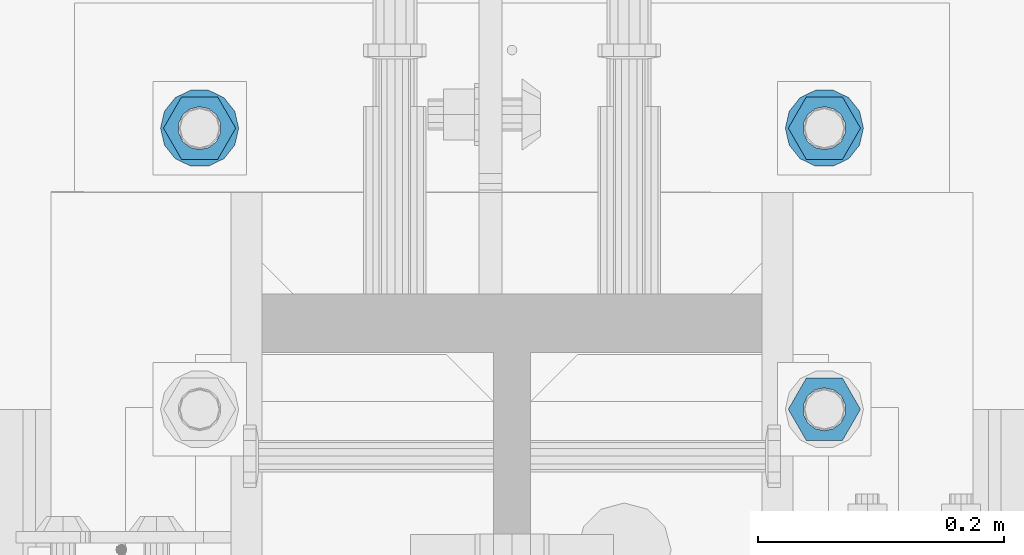
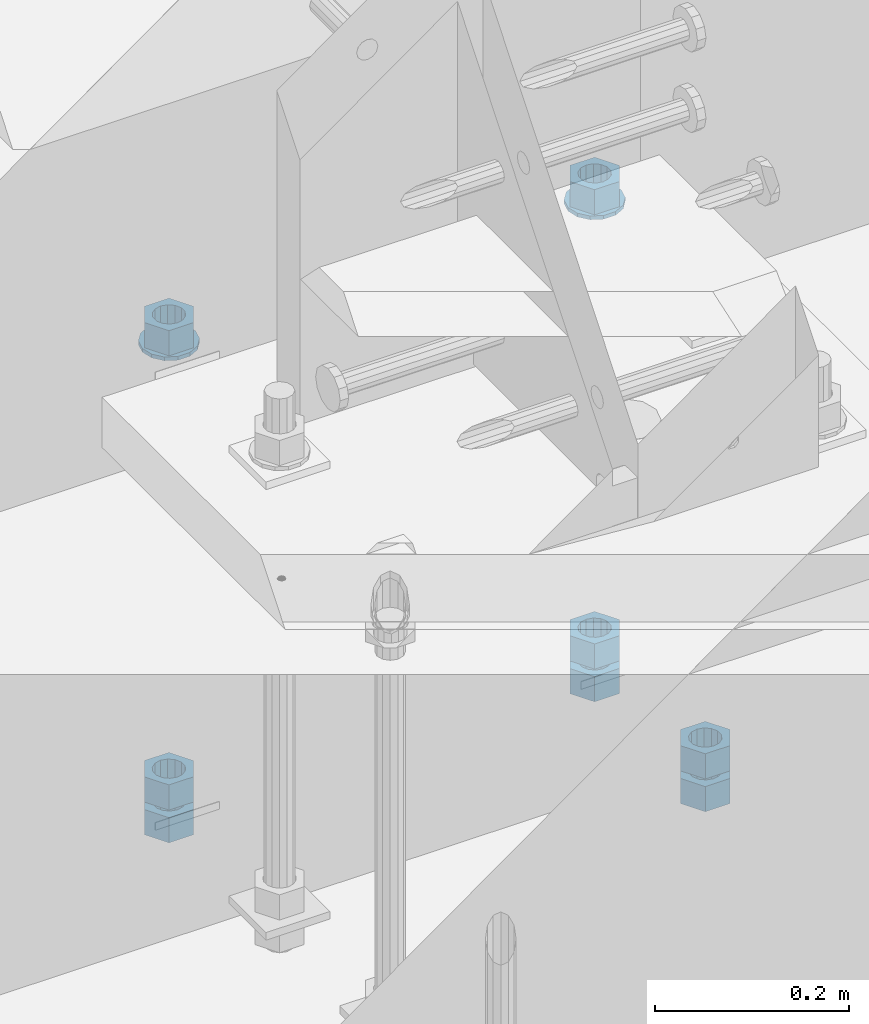
# One storey, part 1015 of 1763: 10 columns, 1 element without a shape of its own.
"""IFC2X3 building model written with IfcOpenShell, lengths in millimetres."""

from ifc_helpers import new_model, si_unit, frame, origin_with_axes, place, context, subcontext, project, spatial, faceted_brep, material, type_object, element, aggregate, save


model = new_model("IFC2X3")

# Units and contexts
model_context = context("Model", 3, precision=1e-05, world=origin_with_axes())
body_context = subcontext(model_context, "Body", "Model", "MODEL_VIEW")
ifc_project = project(units=[si_unit("LENGTHUNIT", "METRE", prefix="MILLI"), si_unit("AREAUNIT", "SQUARE_METRE"), si_unit("VOLUMEUNIT", "CUBIC_METRE"), si_unit("MASSUNIT", "GRAM", prefix="KILO"), si_unit("TIMEUNIT", "SECOND"), si_unit("PLANEANGLEUNIT", "RADIAN"), si_unit("SOLIDANGLEUNIT", "STERADIAN"), si_unit("THERMODYNAMICTEMPERATUREUNIT", "DEGREE_CELSIUS"), si_unit("LUMINOUSINTENSITYUNIT", "LUMEN")], contexts=[model_context])

# Site, building, storey
site_placement = place(None, origin_with_axes())
site = spatial("IfcSite", under=ifc_project, at=site_placement, CompositionType="ELEMENT")
building_placement = place(site_placement, origin_with_axes())
building = spatial("IfcBuilding", under=site, at=building_placement, Name="Undefined", CompositionType="ELEMENT")
storey_placement = place(building_placement, origin_with_axes())
storey = spatial("IfcBuildingStorey", under=building, at=storey_placement, Name="Undefined", CompositionType="ELEMENT", Elevation=0.0)

# Assembly, columns
assembly_placement = place(storey_placement, origin_with_axes())
assembly = element("IfcElementAssembly", 1, at=assembly_placement, inside=storey, Name="TEMPLATE", AssemblyPlace="NOTDEFINED", PredefinedType="RIGID_FRAME")
ifc_material_1 = material(Name="STEEL/A563")
column_type_1 = type_object("IfcColumnType", Name="1-1/4_HEAVY_HEX_NUT", PredefinedType="NOTDEFINED")
column_1_placement = place(assembly_placement, frame((-23773.8372736984, 13804.8999999999, 3384.55), z_axis=(0.0, 1.0, 0.0), x_axis=(0.0, 0.0, -1.0)))
column_1 = element("IfcColumn", 2, at=column_1_placement, type_object=column_type_1, material=ifc_material_1, Name="NUT", ObjectType="1-1/4_HEAVY_HEX_NUT", context=body_context, shape_type="Brep", body=[
    faceted_brep([(0.0, -29.3700008392334, 0.0), (0.0, -14.6800003051758, -25.4300003051758), (31.75, -14.6800003051758, -25.4300003051758), (31.75, -29.3700008392334, 0.0), (0.0, 14.6800003051758, -25.4300003051758), (31.75, 14.6800003051758, -25.4300003051758), (0.0, 29.3700008392334, 0.0), (31.75, 29.3700008392334, 0.0), (0.0, 14.6800003051758, 25.4300003051758), (31.75, 14.6800003051758, 25.4300003051758), (0.0, -14.6800003051758, 25.4300003051758), (31.75, -14.6800003051758, 25.4300003051758), (0.0, 0.0, 17.4599990844727), (0.0, 7.57560968776022, 15.730915608714), (31.75, 7.57560968775942, 15.7309156087145), (31.75, 0.0, 17.4599990844727), (0.0, 13.6507769681037, 10.8861313696252), (31.75, 13.6507769681048, 10.8861313696314), (0.0, 17.0222404541215, 3.88521530314756), (31.75, 17.02224045412, 3.88521530315316), (0.0, 17.0222404541215, -3.88521530314756), (31.75, 17.02224045412, -3.88521530315332), (0.0, 13.6507769681037, -10.8861313696252), (31.75, 13.6507769681048, -10.8861313696316), (0.0, 7.57560968776022, -15.730915608714), (31.75, 7.57560968775942, -15.7309156087146), (0.0, 0.0, -17.4599990844727), (31.75, 0.0, -17.4599990844727), (0.0, -7.57560968776022, -15.730915608714), (31.75, -7.57560968775942, -15.7309156087145), (0.0, -13.6507769681037, -10.8861313696252), (31.75, -13.6507769681048, -10.8861313696314), (0.0, -17.0222404541215, -3.88521530314756), (31.75, -17.02224045412, -3.88521530315316), (0.0, -17.0222404541215, 3.88521530314756), (31.75, -17.02224045412, 3.88521530315332), (0.0, -13.6507769681037, 10.8861313696252), (31.75, -13.6507769681048, 10.8861313696316), (0.0, -7.57560968776022, 15.730915608714), (31.75, -7.57560968775942, 15.7309156087146)], [[[0, 1, 2, 3]], [[1, 4, 5, 2]], [[4, 6, 7, 5]], [[6, 8, 9, 7]], [[8, 10, 11, 9]], [[10, 0, 3, 11]], [[12, 13, 14, 15]], [[13, 16, 17, 14]], [[16, 18, 19, 17]], [[18, 20, 21, 19]], [[20, 22, 23, 21]], [[22, 24, 25, 23]], [[24, 26, 27, 25]], [[26, 28, 29, 27]], [[28, 30, 31, 29]], [[30, 32, 33, 31]], [[32, 34, 35, 33]], [[34, 36, 37, 35]], [[36, 38, 39, 37]], [[38, 12, 15, 39]], [[5, 7, 9, 11, 3, 2], [17, 19, 21, 23, 25, 27, 29, 31, 33, 35, 37, 39, 15, 14]], [[10, 8, 6, 4, 1, 0], [38, 36, 34, 32, 30, 28, 26, 24, 22, 20, 18, 16, 13, 12]]]),
])
column_2_placement = place(assembly_placement, frame((-23773.8372736984, 13804.8999999999, 3343.275), z_axis=(0.0, 1.0, 0.0), x_axis=(0.0, 0.0, -1.0)))
column_2 = element("IfcColumn", 3, at=column_2_placement, type_object=column_type_1, material=ifc_material_1, Name="NUT", ObjectType="1-1/4_HEAVY_HEX_NUT", context=body_context, shape_type="Brep", body=[
    faceted_brep([(0.0, -29.3700008392334, 0.0), (0.0, -14.6800003051758, -25.4300003051758), (31.75, -14.6800003051758, -25.4300003051758), (31.75, -29.3700008392334, 0.0), (0.0, 14.6800003051758, -25.4300003051758), (31.75, 14.6800003051758, -25.4300003051758), (0.0, 29.3700008392334, 0.0), (31.75, 29.3700008392334, 0.0), (0.0, 14.6800003051758, 25.4300003051758), (31.75, 14.6800003051758, 25.4300003051758), (0.0, -14.6800003051758, 25.4300003051758), (31.75, -14.6800003051758, 25.4300003051758), (0.0, 0.0, 17.4599990844727), (0.0, 7.57560968776022, 15.730915608714), (31.75, 7.57560968775942, 15.7309156087145), (31.75, 0.0, 17.4599990844727), (0.0, 13.6507769681037, 10.8861313696252), (31.75, 13.6507769681048, 10.8861313696314), (0.0, 17.0222404541215, 3.88521530314756), (31.75, 17.02224045412, 3.88521530315316), (0.0, 17.0222404541215, -3.88521530314756), (31.75, 17.02224045412, -3.88521530315332), (0.0, 13.6507769681037, -10.8861313696252), (31.75, 13.6507769681048, -10.8861313696316), (0.0, 7.57560968776022, -15.730915608714), (31.75, 7.57560968775942, -15.7309156087146), (0.0, 0.0, -17.4599990844727), (31.75, 0.0, -17.4599990844727), (0.0, -7.57560968776022, -15.730915608714), (31.75, -7.57560968775942, -15.7309156087145), (0.0, -13.6507769681037, -10.8861313696252), (31.75, -13.6507769681048, -10.8861313696314), (0.0, -17.0222404541215, -3.88521530314756), (31.75, -17.02224045412, -3.88521530315316), (0.0, -17.0222404541215, 3.88521530314756), (31.75, -17.02224045412, 3.88521530315332), (0.0, -13.6507769681037, 10.8861313696252), (31.75, -13.6507769681048, 10.8861313696316), (0.0, -7.57560968776022, 15.730915608714), (31.75, -7.57560968775942, 15.7309156087146)], [[[0, 1, 2, 3]], [[1, 4, 5, 2]], [[4, 6, 7, 5]], [[6, 8, 9, 7]], [[8, 10, 11, 9]], [[10, 0, 3, 11]], [[12, 13, 14, 15]], [[13, 16, 17, 14]], [[16, 18, 19, 17]], [[18, 20, 21, 19]], [[20, 22, 23, 21]], [[22, 24, 25, 23]], [[24, 26, 27, 25]], [[26, 28, 29, 27]], [[28, 30, 31, 29]], [[30, 32, 33, 31]], [[32, 34, 35, 33]], [[34, 36, 37, 35]], [[36, 38, 39, 37]], [[38, 12, 15, 39]], [[5, 7, 9, 11, 3, 2], [17, 19, 21, 23, 25, 27, 29, 31, 33, 35, 37, 39, 15, 14]], [[10, 8, 6, 4, 1, 0], [38, 36, 34, 32, 30, 28, 26, 24, 22, 20, 18, 16, 13, 12]]]),
])
column_3_placement = place(assembly_placement, frame((-24281.8372736984, 14033.4999999999, 3957.6375), z_axis=(0.0, -1.0, 0.0), x_axis=(0.0, 0.0, -1.0)))
column_3 = element("IfcColumn", 4, at=column_3_placement, type_object=column_type_1, material=ifc_material_1, Name="NUT", ObjectType="1-1/4_HEAVY_HEX_NUT", context=body_context, shape_type="Brep", body=[
    faceted_brep([(0.0, -29.3700008392334, 0.0), (0.0, -14.6800003051758, -25.4300003051758), (31.75, -14.6800003051758, -25.4300003051758), (31.75, -29.3700008392334, 0.0), (0.0, 14.6800003051758, -25.4300003051758), (31.75, 14.6800003051758, -25.4300003051758), (0.0, 29.3700008392334, 0.0), (31.75, 29.3700008392334, 0.0), (0.0, 14.6800003051758, 25.4300003051758), (31.75, 14.6800003051758, 25.4300003051758), (0.0, -14.6800003051758, 25.4300003051758), (31.75, -14.6800003051758, 25.4300003051758), (0.0, 0.0, 17.4599990844727), (0.0, 7.57560968776022, 15.730915608714), (31.75, 7.57560968775942, 15.7309156087145), (31.75, 0.0, 17.4599990844727), (0.0, 13.6507769681037, 10.8861313696252), (31.75, 13.6507769681048, 10.8861313696314), (0.0, 17.0222404541215, 3.88521530314756), (31.75, 17.02224045412, 3.88521530315316), (0.0, 17.0222404541215, -3.88521530314756), (31.75, 17.02224045412, -3.88521530315332), (0.0, 13.6507769681037, -10.8861313696252), (31.75, 13.6507769681048, -10.8861313696316), (0.0, 7.57560968776022, -15.730915608714), (31.75, 7.57560968775942, -15.7309156087146), (0.0, 0.0, -17.4599990844727), (31.75, 0.0, -17.4599990844727), (0.0, -7.57560968776022, -15.730915608714), (31.75, -7.57560968775942, -15.7309156087145), (0.0, -13.6507769681037, -10.8861313696252), (31.75, -13.6507769681048, -10.8861313696314), (0.0, -17.0222404541215, -3.88521530314756), (31.75, -17.02224045412, -3.88521530315316), (0.0, -17.0222404541215, 3.88521530314756), (31.75, -17.02224045412, 3.88521530315332), (0.0, -13.6507769681037, 10.8861313696252), (31.75, -13.6507769681048, 10.8861313696316), (0.0, -7.57560968776022, 15.730915608714), (31.75, -7.57560968775942, 15.7309156087146)], [[[0, 1, 2, 3]], [[1, 4, 5, 2]], [[4, 6, 7, 5]], [[6, 8, 9, 7]], [[8, 10, 11, 9]], [[10, 0, 3, 11]], [[12, 13, 14, 15]], [[13, 16, 17, 14]], [[16, 18, 19, 17]], [[18, 20, 21, 19]], [[20, 22, 23, 21]], [[22, 24, 25, 23]], [[24, 26, 27, 25]], [[26, 28, 29, 27]], [[28, 30, 31, 29]], [[30, 32, 33, 31]], [[32, 34, 35, 33]], [[34, 36, 37, 35]], [[36, 38, 39, 37]], [[38, 12, 15, 39]], [[5, 7, 9, 11, 3, 2], [17, 19, 21, 23, 25, 27, 29, 31, 33, 35, 37, 39, 15, 14]], [[10, 8, 6, 4, 1, 0], [38, 36, 34, 32, 30, 28, 26, 24, 22, 20, 18, 16, 13, 12]]]),
])
column_4_placement = place(assembly_placement, frame((-24281.8372736984, 14033.4999999999, 3384.55), z_axis=(0.0, -1.0, 0.0), x_axis=(0.0, 0.0, -1.0)))
column_4 = element("IfcColumn", 5, at=column_4_placement, type_object=column_type_1, material=ifc_material_1, Name="NUT", ObjectType="1-1/4_HEAVY_HEX_NUT", context=body_context, shape_type="Brep", body=[
    faceted_brep([(0.0, -29.3700008392334, 0.0), (0.0, -14.6800003051758, -25.4300003051758), (31.75, -14.6800003051758, -25.4300003051758), (31.75, -29.3700008392334, 0.0), (0.0, 14.6800003051758, -25.4300003051758), (31.75, 14.6800003051758, -25.4300003051758), (0.0, 29.3700008392334, 0.0), (31.75, 29.3700008392334, 0.0), (0.0, 14.6800003051758, 25.4300003051758), (31.75, 14.6800003051758, 25.4300003051758), (0.0, -14.6800003051758, 25.4300003051758), (31.75, -14.6800003051758, 25.4300003051758), (0.0, 0.0, 17.4599990844727), (0.0, 7.57560968776022, 15.730915608714), (31.75, 7.57560968775942, 15.7309156087145), (31.75, 0.0, 17.4599990844727), (0.0, 13.6507769681037, 10.8861313696252), (31.75, 13.6507769681048, 10.8861313696314), (0.0, 17.0222404541215, 3.88521530314756), (31.75, 17.02224045412, 3.88521530315316), (0.0, 17.0222404541215, -3.88521530314756), (31.75, 17.02224045412, -3.88521530315332), (0.0, 13.6507769681037, -10.8861313696252), (31.75, 13.6507769681048, -10.8861313696316), (0.0, 7.57560968776022, -15.730915608714), (31.75, 7.57560968775942, -15.7309156087146), (0.0, 0.0, -17.4599990844727), (31.75, 0.0, -17.4599990844727), (0.0, -7.57560968776022, -15.730915608714), (31.75, -7.57560968775942, -15.7309156087145), (0.0, -13.6507769681037, -10.8861313696252), (31.75, -13.6507769681048, -10.8861313696314), (0.0, -17.0222404541215, -3.88521530314756), (31.75, -17.02224045412, -3.88521530315316), (0.0, -17.0222404541215, 3.88521530314756), (31.75, -17.02224045412, 3.88521530315332), (0.0, -13.6507769681037, 10.8861313696252), (31.75, -13.6507769681048, 10.8861313696316), (0.0, -7.57560968776022, 15.730915608714), (31.75, -7.57560968775942, 15.7309156087146)], [[[0, 1, 2, 3]], [[1, 4, 5, 2]], [[4, 6, 7, 5]], [[6, 8, 9, 7]], [[8, 10, 11, 9]], [[10, 0, 3, 11]], [[12, 13, 14, 15]], [[13, 16, 17, 14]], [[16, 18, 19, 17]], [[18, 20, 21, 19]], [[20, 22, 23, 21]], [[22, 24, 25, 23]], [[24, 26, 27, 25]], [[26, 28, 29, 27]], [[28, 30, 31, 29]], [[30, 32, 33, 31]], [[32, 34, 35, 33]], [[34, 36, 37, 35]], [[36, 38, 39, 37]], [[38, 12, 15, 39]], [[5, 7, 9, 11, 3, 2], [17, 19, 21, 23, 25, 27, 29, 31, 33, 35, 37, 39, 15, 14]], [[10, 8, 6, 4, 1, 0], [38, 36, 34, 32, 30, 28, 26, 24, 22, 20, 18, 16, 13, 12]]]),
])
column_5_placement = place(assembly_placement, frame((-24281.8372736984, 14033.4999999999, 3343.275), z_axis=(0.0, -1.0, 0.0), x_axis=(0.0, 0.0, -1.0)))
column_5 = element("IfcColumn", 6, at=column_5_placement, type_object=column_type_1, material=ifc_material_1, Name="NUT", ObjectType="1-1/4_HEAVY_HEX_NUT", context=body_context, shape_type="Brep", body=[
    faceted_brep([(0.0, -29.3700008392334, 0.0), (0.0, -14.6800003051758, -25.4300003051758), (31.75, -14.6800003051758, -25.4300003051758), (31.75, -29.3700008392334, 0.0), (0.0, 14.6800003051758, -25.4300003051758), (31.75, 14.6800003051758, -25.4300003051758), (0.0, 29.3700008392334, 0.0), (31.75, 29.3700008392334, 0.0), (0.0, 14.6800003051758, 25.4300003051758), (31.75, 14.6800003051758, 25.4300003051758), (0.0, -14.6800003051758, 25.4300003051758), (31.75, -14.6800003051758, 25.4300003051758), (0.0, 0.0, 17.4599990844727), (0.0, 7.57560968776022, 15.730915608714), (31.75, 7.57560968775942, 15.7309156087145), (31.75, 0.0, 17.4599990844727), (0.0, 13.6507769681037, 10.8861313696252), (31.75, 13.6507769681048, 10.8861313696314), (0.0, 17.0222404541215, 3.88521530314756), (31.75, 17.02224045412, 3.88521530315316), (0.0, 17.0222404541215, -3.88521530314756), (31.75, 17.02224045412, -3.88521530315332), (0.0, 13.6507769681037, -10.8861313696252), (31.75, 13.6507769681048, -10.8861313696316), (0.0, 7.57560968776022, -15.730915608714), (31.75, 7.57560968775942, -15.7309156087146), (0.0, 0.0, -17.4599990844727), (31.75, 0.0, -17.4599990844727), (0.0, -7.57560968776022, -15.730915608714), (31.75, -7.57560968775942, -15.7309156087145), (0.0, -13.6507769681037, -10.8861313696252), (31.75, -13.6507769681048, -10.8861313696314), (0.0, -17.0222404541215, -3.88521530314756), (31.75, -17.02224045412, -3.88521530315316), (0.0, -17.0222404541215, 3.88521530314756), (31.75, -17.02224045412, 3.88521530315332), (0.0, -13.6507769681037, 10.8861313696252), (31.75, -13.6507769681048, 10.8861313696316), (0.0, -7.57560968776022, 15.730915608714), (31.75, -7.57560968775942, 15.7309156087146)], [[[0, 1, 2, 3]], [[1, 4, 5, 2]], [[4, 6, 7, 5]], [[6, 8, 9, 7]], [[8, 10, 11, 9]], [[10, 0, 3, 11]], [[12, 13, 14, 15]], [[13, 16, 17, 14]], [[16, 18, 19, 17]], [[18, 20, 21, 19]], [[20, 22, 23, 21]], [[22, 24, 25, 23]], [[24, 26, 27, 25]], [[26, 28, 29, 27]], [[28, 30, 31, 29]], [[30, 32, 33, 31]], [[32, 34, 35, 33]], [[34, 36, 37, 35]], [[36, 38, 39, 37]], [[38, 12, 15, 39]], [[5, 7, 9, 11, 3, 2], [17, 19, 21, 23, 25, 27, 29, 31, 33, 35, 37, 39, 15, 14]], [[10, 8, 6, 4, 1, 0], [38, 36, 34, 32, 30, 28, 26, 24, 22, 20, 18, 16, 13, 12]]]),
])
column_6_placement = place(assembly_placement, frame((-23773.8372736984, 14033.4999999999, 3957.6375), z_axis=(0.0, 1.0, 0.0), x_axis=(0.0, 0.0, -1.0)))
column_6 = element("IfcColumn", 7, at=column_6_placement, type_object=column_type_1, material=ifc_material_1, Name="NUT", ObjectType="1-1/4_HEAVY_HEX_NUT", context=body_context, shape_type="Brep", body=[
    faceted_brep([(0.0, -29.3700008392334, 0.0), (0.0, -14.6800003051758, -25.4300003051758), (31.75, -14.6800003051758, -25.4300003051758), (31.75, -29.3700008392334, 0.0), (0.0, 14.6800003051758, -25.4300003051758), (31.75, 14.6800003051758, -25.4300003051758), (0.0, 29.3700008392334, 0.0), (31.75, 29.3700008392334, 0.0), (0.0, 14.6800003051758, 25.4300003051758), (31.75, 14.6800003051758, 25.4300003051758), (0.0, -14.6800003051758, 25.4300003051758), (31.75, -14.6800003051758, 25.4300003051758), (0.0, 0.0, 17.4599990844727), (0.0, 7.57560968776022, 15.730915608714), (31.75, 7.57560968775942, 15.7309156087145), (31.75, 0.0, 17.4599990844727), (0.0, 13.6507769681037, 10.8861313696252), (31.75, 13.6507769681048, 10.8861313696314), (0.0, 17.0222404541215, 3.88521530314756), (31.75, 17.02224045412, 3.88521530315316), (0.0, 17.0222404541215, -3.88521530314756), (31.75, 17.02224045412, -3.88521530315332), (0.0, 13.6507769681037, -10.8861313696252), (31.75, 13.6507769681048, -10.8861313696316), (0.0, 7.57560968776022, -15.730915608714), (31.75, 7.57560968775942, -15.7309156087146), (0.0, 0.0, -17.4599990844727), (31.75, 0.0, -17.4599990844727), (0.0, -7.57560968776022, -15.730915608714), (31.75, -7.57560968775942, -15.7309156087145), (0.0, -13.6507769681037, -10.8861313696252), (31.75, -13.6507769681048, -10.8861313696314), (0.0, -17.0222404541215, -3.88521530314756), (31.75, -17.02224045412, -3.88521530315316), (0.0, -17.0222404541215, 3.88521530314756), (31.75, -17.02224045412, 3.88521530315332), (0.0, -13.6507769681037, 10.8861313696252), (31.75, -13.6507769681048, 10.8861313696316), (0.0, -7.57560968776022, 15.730915608714), (31.75, -7.57560968775942, 15.7309156087146)], [[[0, 1, 2, 3]], [[1, 4, 5, 2]], [[4, 6, 7, 5]], [[6, 8, 9, 7]], [[8, 10, 11, 9]], [[10, 0, 3, 11]], [[12, 13, 14, 15]], [[13, 16, 17, 14]], [[16, 18, 19, 17]], [[18, 20, 21, 19]], [[20, 22, 23, 21]], [[22, 24, 25, 23]], [[24, 26, 27, 25]], [[26, 28, 29, 27]], [[28, 30, 31, 29]], [[30, 32, 33, 31]], [[32, 34, 35, 33]], [[34, 36, 37, 35]], [[36, 38, 39, 37]], [[38, 12, 15, 39]], [[5, 7, 9, 11, 3, 2], [17, 19, 21, 23, 25, 27, 29, 31, 33, 35, 37, 39, 15, 14]], [[10, 8, 6, 4, 1, 0], [38, 36, 34, 32, 30, 28, 26, 24, 22, 20, 18, 16, 13, 12]]]),
])
column_7_placement = place(assembly_placement, frame((-23773.8372736984, 14033.4999999999, 3384.55), z_axis=(0.0, 1.0, 0.0), x_axis=(0.0, 0.0, -1.0)))
column_7 = element("IfcColumn", 8, at=column_7_placement, type_object=column_type_1, material=ifc_material_1, Name="NUT", ObjectType="1-1/4_HEAVY_HEX_NUT", context=body_context, shape_type="Brep", body=[
    faceted_brep([(0.0, -29.3700008392334, 0.0), (0.0, -14.6800003051758, -25.4300003051758), (31.75, -14.6800003051758, -25.4300003051758), (31.75, -29.3700008392334, 0.0), (0.0, 14.6800003051758, -25.4300003051758), (31.75, 14.6800003051758, -25.4300003051758), (0.0, 29.3700008392334, 0.0), (31.75, 29.3700008392334, 0.0), (0.0, 14.6800003051758, 25.4300003051758), (31.75, 14.6800003051758, 25.4300003051758), (0.0, -14.6800003051758, 25.4300003051758), (31.75, -14.6800003051758, 25.4300003051758), (0.0, 0.0, 17.4599990844727), (0.0, 7.57560968776022, 15.730915608714), (31.75, 7.57560968775942, 15.7309156087145), (31.75, 0.0, 17.4599990844727), (0.0, 13.6507769681037, 10.8861313696252), (31.75, 13.6507769681048, 10.8861313696314), (0.0, 17.0222404541215, 3.88521530314756), (31.75, 17.02224045412, 3.88521530315316), (0.0, 17.0222404541215, -3.88521530314756), (31.75, 17.02224045412, -3.88521530315332), (0.0, 13.6507769681037, -10.8861313696252), (31.75, 13.6507769681048, -10.8861313696316), (0.0, 7.57560968776022, -15.730915608714), (31.75, 7.57560968775942, -15.7309156087146), (0.0, 0.0, -17.4599990844727), (31.75, 0.0, -17.4599990844727), (0.0, -7.57560968776022, -15.730915608714), (31.75, -7.57560968775942, -15.7309156087145), (0.0, -13.6507769681037, -10.8861313696252), (31.75, -13.6507769681048, -10.8861313696314), (0.0, -17.0222404541215, -3.88521530314756), (31.75, -17.02224045412, -3.88521530315316), (0.0, -17.0222404541215, 3.88521530314756), (31.75, -17.02224045412, 3.88521530315332), (0.0, -13.6507769681037, 10.8861313696252), (31.75, -13.6507769681048, 10.8861313696316), (0.0, -7.57560968776022, 15.730915608714), (31.75, -7.57560968775942, 15.7309156087146)], [[[0, 1, 2, 3]], [[1, 4, 5, 2]], [[4, 6, 7, 5]], [[6, 8, 9, 7]], [[8, 10, 11, 9]], [[10, 0, 3, 11]], [[12, 13, 14, 15]], [[13, 16, 17, 14]], [[16, 18, 19, 17]], [[18, 20, 21, 19]], [[20, 22, 23, 21]], [[22, 24, 25, 23]], [[24, 26, 27, 25]], [[26, 28, 29, 27]], [[28, 30, 31, 29]], [[30, 32, 33, 31]], [[32, 34, 35, 33]], [[34, 36, 37, 35]], [[36, 38, 39, 37]], [[38, 12, 15, 39]], [[5, 7, 9, 11, 3, 2], [17, 19, 21, 23, 25, 27, 29, 31, 33, 35, 37, 39, 15, 14]], [[10, 8, 6, 4, 1, 0], [38, 36, 34, 32, 30, 28, 26, 24, 22, 20, 18, 16, 13, 12]]]),
])
column_8_placement = place(assembly_placement, frame((-23773.8372736984, 14033.4999999999, 3343.275), z_axis=(0.0, 1.0, 0.0), x_axis=(0.0, 0.0, -1.0)))
column_8 = element("IfcColumn", 9, at=column_8_placement, type_object=column_type_1, material=ifc_material_1, Name="NUT", ObjectType="1-1/4_HEAVY_HEX_NUT", context=body_context, shape_type="Brep", body=[
    faceted_brep([(0.0, -29.3700008392334, 0.0), (0.0, -14.6800003051758, -25.4300003051758), (31.75, -14.6800003051758, -25.4300003051758), (31.75, -29.3700008392334, 0.0), (0.0, 14.6800003051758, -25.4300003051758), (31.75, 14.6800003051758, -25.4300003051758), (0.0, 29.3700008392334, 0.0), (31.75, 29.3700008392334, 0.0), (0.0, 14.6800003051758, 25.4300003051758), (31.75, 14.6800003051758, 25.4300003051758), (0.0, -14.6800003051758, 25.4300003051758), (31.75, -14.6800003051758, 25.4300003051758), (0.0, 0.0, 17.4599990844727), (0.0, 7.57560968776022, 15.730915608714), (31.75, 7.57560968775942, 15.7309156087145), (31.75, 0.0, 17.4599990844727), (0.0, 13.6507769681037, 10.8861313696252), (31.75, 13.6507769681048, 10.8861313696314), (0.0, 17.0222404541215, 3.88521530314756), (31.75, 17.02224045412, 3.88521530315316), (0.0, 17.0222404541215, -3.88521530314756), (31.75, 17.02224045412, -3.88521530315332), (0.0, 13.6507769681037, -10.8861313696252), (31.75, 13.6507769681048, -10.8861313696316), (0.0, 7.57560968776022, -15.730915608714), (31.75, 7.57560968775942, -15.7309156087146), (0.0, 0.0, -17.4599990844727), (31.75, 0.0, -17.4599990844727), (0.0, -7.57560968776022, -15.730915608714), (31.75, -7.57560968775942, -15.7309156087145), (0.0, -13.6507769681037, -10.8861313696252), (31.75, -13.6507769681048, -10.8861313696314), (0.0, -17.0222404541215, -3.88521530314756), (31.75, -17.02224045412, -3.88521530315316), (0.0, -17.0222404541215, 3.88521530314756), (31.75, -17.02224045412, 3.88521530315332), (0.0, -13.6507769681037, 10.8861313696252), (31.75, -13.6507769681048, 10.8861313696316), (0.0, -7.57560968776022, 15.730915608714), (31.75, -7.57560968775942, 15.7309156087146)], [[[0, 1, 2, 3]], [[1, 4, 5, 2]], [[4, 6, 7, 5]], [[6, 8, 9, 7]], [[8, 10, 11, 9]], [[10, 0, 3, 11]], [[12, 13, 14, 15]], [[13, 16, 17, 14]], [[16, 18, 19, 17]], [[18, 20, 21, 19]], [[20, 22, 23, 21]], [[22, 24, 25, 23]], [[24, 26, 27, 25]], [[26, 28, 29, 27]], [[28, 30, 31, 29]], [[30, 32, 33, 31]], [[32, 34, 35, 33]], [[34, 36, 37, 35]], [[36, 38, 39, 37]], [[38, 12, 15, 39]], [[5, 7, 9, 11, 3, 2], [17, 19, 21, 23, 25, 27, 29, 31, 33, 35, 37, 39, 15, 14]], [[10, 8, 6, 4, 1, 0], [38, 36, 34, 32, 30, 28, 26, 24, 22, 20, 18, 16, 13, 12]]]),
])
ifc_material_2 = material(Name="STEEL/F436")
column_type_2 = type_object("IfcColumnType", Name="1-1/4_WASHER", PredefinedType="NOTDEFINED")
column_9_placement = place(assembly_placement, frame((-24281.8372736984, 14033.4999999999, 3925.8875), z_axis=(0.0, -1.0, 0.0), x_axis=(0.0, 0.0, -1.0)))
column_9 = element("IfcColumn", 10, at=column_9_placement, type_object=column_type_2, material=ifc_material_2, Name="WASHER", ObjectType="1-1/4_WASHER", context=body_context, shape_type="Brep", body=[
    faceted_brep([(-4.54747350886464e-13, -31.7499999999964, 0.0), (0.0, -28.6057615559002, -13.7758087169827), (4.76249999999982, -28.6057615559002, -13.7758087169827), (4.76249999999982, -31.75, 0.0), (0.0, -19.795801209013, -24.8231495683602), (4.76249999999982, -19.795801209013, -24.8231495683602), (0.0, -7.06503965311276, -30.9539612117732), (4.76249999999982, -7.06503965311276, -30.9539612117732), (0.0, 7.06503965311276, -30.9539612117732), (4.76249999999982, 7.06503965311276, -30.9539612117732), (0.0, 19.7958012090166, -24.8231495683602), (4.76249999999982, 19.7958012090166, -24.8231495683602), (0.0, 28.6057615559039, -13.7758087169827), (4.76249999999982, 28.6057615559039, -13.7758087169827), (-5.91171556152403e-12, 31.7499999999891, 0.0), (4.76249999999982, 31.75, 0.0), (0.0, 28.6057615559002, 13.7758087169827), (4.76249999999982, 28.6057615559002, 13.7758087169827), (0.0, 19.795801209013, 24.8231495683602), (4.76249999999982, 19.795801209013, 24.8231495683602), (0.0, 7.06503965311276, 30.9539612117731), (4.76249999999982, 7.06503965311276, 30.9539612117731), (0.0, -7.06503965311276, 30.9539612117731), (4.76249999999982, -7.06503965311276, 30.9539612117731), (0.0, -19.7958012090166, 24.8231495683602), (4.76249999999982, -19.7958012090166, 24.8231495683602), (0.0, -28.6057615559039, 13.7758087169827), (4.76249999999982, -28.6057615559039, 13.7758087169827), (0.0, 0.0, 17.4599990844727), (0.0, 7.57560968776022, 15.730915608714), (4.76249999999982, 7.57560968775942, 15.7309156087145), (4.76249999999982, 0.0, 17.4599990844727), (0.0, 13.6507769681037, 10.8861313696252), (4.76249999999982, 13.6507769681048, 10.8861313696314), (0.0, 17.0222404541215, 3.88521530314756), (4.76249999999982, 17.02224045412, 3.88521530315316), (0.0, 17.0222404541215, -3.88521530314756), (4.76249999999982, 17.02224045412, -3.88521530315332), (0.0, 13.6507769681037, -10.8861313696252), (4.76249999999982, 13.6507769681048, -10.8861313696316), (0.0, 7.57560968776022, -15.730915608714), (4.76249999999982, 7.57560968775942, -15.7309156087146), (0.0, 0.0, -17.4599990844727), (4.76249999999982, 0.0, -17.4599990844727), (0.0, -7.57560968776022, -15.730915608714), (4.76249999999982, -7.57560968775942, -15.7309156087145), (0.0, -13.6507769681037, -10.8861313696252), (4.76249999999982, -13.6507769681048, -10.8861313696314), (0.0, -17.0222404541215, -3.88521530314756), (4.76249999999982, -17.02224045412, -3.88521530315316), (0.0, -17.0222404541215, 3.88521530314756), (4.76249999999982, -17.02224045412, 3.88521530315332), (0.0, -13.6507769681037, 10.8861313696252), (4.76249999999982, -13.6507769681048, 10.8861313696316), (0.0, -7.57560968776022, 15.730915608714), (4.76249999999982, -7.57560968775942, 15.7309156087146)], [[[0, 1, 2, 3]], [[1, 4, 5, 2]], [[4, 6, 7, 5]], [[6, 8, 9, 7]], [[8, 10, 11, 9]], [[10, 12, 13, 11]], [[12, 14, 15, 13]], [[14, 16, 17, 15]], [[16, 18, 19, 17]], [[18, 20, 21, 19]], [[20, 22, 23, 21]], [[22, 24, 25, 23]], [[24, 26, 27, 25]], [[26, 0, 3, 27]], [[28, 29, 30, 31]], [[29, 32, 33, 30]], [[32, 34, 35, 33]], [[34, 36, 37, 35]], [[36, 38, 39, 37]], [[38, 40, 41, 39]], [[40, 42, 43, 41]], [[42, 44, 45, 43]], [[44, 46, 47, 45]], [[46, 48, 49, 47]], [[48, 50, 51, 49]], [[50, 52, 53, 51]], [[52, 54, 55, 53]], [[54, 28, 31, 55]], [[5, 7, 9, 11, 13, 15, 17, 19, 21, 23, 25, 27, 3, 2], [33, 35, 37, 39, 41, 43, 45, 47, 49, 51, 53, 55, 31, 30]], [[26, 24, 22, 20, 18, 16, 14, 12, 10, 8, 6, 4, 1, 0], [54, 52, 50, 48, 46, 44, 42, 40, 38, 36, 34, 32, 29, 28]]]),
])
column_10_placement = place(assembly_placement, frame((-23773.8372736984, 14033.4999999999, 3925.8875), z_axis=(0.0, 1.0, 0.0), x_axis=(0.0, 0.0, -1.0)))
column_10 = element("IfcColumn", 11, at=column_10_placement, type_object=column_type_2, material=ifc_material_2, Name="WASHER", ObjectType="1-1/4_WASHER", context=body_context, shape_type="Brep", body=[
    faceted_brep([(-4.54747350886464e-13, -31.7499999999964, 0.0), (0.0, -28.6057615559002, -13.7758087169827), (4.76249999999982, -28.6057615559002, -13.7758087169827), (4.76249999999982, -31.75, 0.0), (0.0, -19.795801209013, -24.8231495683602), (4.76249999999982, -19.795801209013, -24.8231495683602), (0.0, -7.06503965311276, -30.9539612117732), (4.76249999999982, -7.06503965311276, -30.9539612117732), (0.0, 7.06503965311276, -30.9539612117732), (4.76249999999982, 7.06503965311276, -30.9539612117732), (0.0, 19.7958012090166, -24.8231495683602), (4.76249999999982, 19.7958012090166, -24.8231495683602), (0.0, 28.6057615559039, -13.7758087169827), (4.76249999999982, 28.6057615559039, -13.7758087169827), (-5.91171556152403e-12, 31.7499999999891, 0.0), (4.76249999999982, 31.75, 0.0), (0.0, 28.6057615559002, 13.7758087169827), (4.76249999999982, 28.6057615559002, 13.7758087169827), (0.0, 19.795801209013, 24.8231495683602), (4.76249999999982, 19.795801209013, 24.8231495683602), (0.0, 7.06503965311276, 30.9539612117731), (4.76249999999982, 7.06503965311276, 30.9539612117731), (0.0, -7.06503965311276, 30.9539612117731), (4.76249999999982, -7.06503965311276, 30.9539612117731), (0.0, -19.7958012090166, 24.8231495683602), (4.76249999999982, -19.7958012090166, 24.8231495683602), (0.0, -28.6057615559039, 13.7758087169827), (4.76249999999982, -28.6057615559039, 13.7758087169827), (0.0, 0.0, 17.4599990844727), (0.0, 7.57560968776022, 15.730915608714), (4.76249999999982, 7.57560968775942, 15.7309156087145), (4.76249999999982, 0.0, 17.4599990844727), (0.0, 13.6507769681037, 10.8861313696252), (4.76249999999982, 13.6507769681048, 10.8861313696314), (0.0, 17.0222404541215, 3.88521530314756), (4.76249999999982, 17.02224045412, 3.88521530315316), (0.0, 17.0222404541215, -3.88521530314756), (4.76249999999982, 17.02224045412, -3.88521530315332), (0.0, 13.6507769681037, -10.8861313696252), (4.76249999999982, 13.6507769681048, -10.8861313696316), (0.0, 7.57560968776022, -15.730915608714), (4.76249999999982, 7.57560968775942, -15.7309156087146), (0.0, 0.0, -17.4599990844727), (4.76249999999982, 0.0, -17.4599990844727), (0.0, -7.57560968776022, -15.730915608714), (4.76249999999982, -7.57560968775942, -15.7309156087145), (0.0, -13.6507769681037, -10.8861313696252), (4.76249999999982, -13.6507769681048, -10.8861313696314), (0.0, -17.0222404541215, -3.88521530314756), (4.76249999999982, -17.02224045412, -3.88521530315316), (0.0, -17.0222404541215, 3.88521530314756), (4.76249999999982, -17.02224045412, 3.88521530315332), (0.0, -13.6507769681037, 10.8861313696252), (4.76249999999982, -13.6507769681048, 10.8861313696316), (0.0, -7.57560968776022, 15.730915608714), (4.76249999999982, -7.57560968775942, 15.7309156087146)], [[[0, 1, 2, 3]], [[1, 4, 5, 2]], [[4, 6, 7, 5]], [[6, 8, 9, 7]], [[8, 10, 11, 9]], [[10, 12, 13, 11]], [[12, 14, 15, 13]], [[14, 16, 17, 15]], [[16, 18, 19, 17]], [[18, 20, 21, 19]], [[20, 22, 23, 21]], [[22, 24, 25, 23]], [[24, 26, 27, 25]], [[26, 0, 3, 27]], [[28, 29, 30, 31]], [[29, 32, 33, 30]], [[32, 34, 35, 33]], [[34, 36, 37, 35]], [[36, 38, 39, 37]], [[38, 40, 41, 39]], [[40, 42, 43, 41]], [[42, 44, 45, 43]], [[44, 46, 47, 45]], [[46, 48, 49, 47]], [[48, 50, 51, 49]], [[50, 52, 53, 51]], [[52, 54, 55, 53]], [[54, 28, 31, 55]], [[5, 7, 9, 11, 13, 15, 17, 19, 21, 23, 25, 27, 3, 2], [33, 35, 37, 39, 41, 43, 45, 47, 49, 51, 53, 55, 31, 30]], [[26, 24, 22, 20, 18, 16, 14, 12, 10, 8, 6, 4, 1, 0], [54, 52, 50, 48, 46, 44, 42, 40, 38, 36, 34, 32, 29, 28]]]),
])
aggregate(assembly, [column_1, column_2, column_3, column_9, column_4, column_5, column_6, column_10, column_7, column_8])

save(model, "model.ifc")
